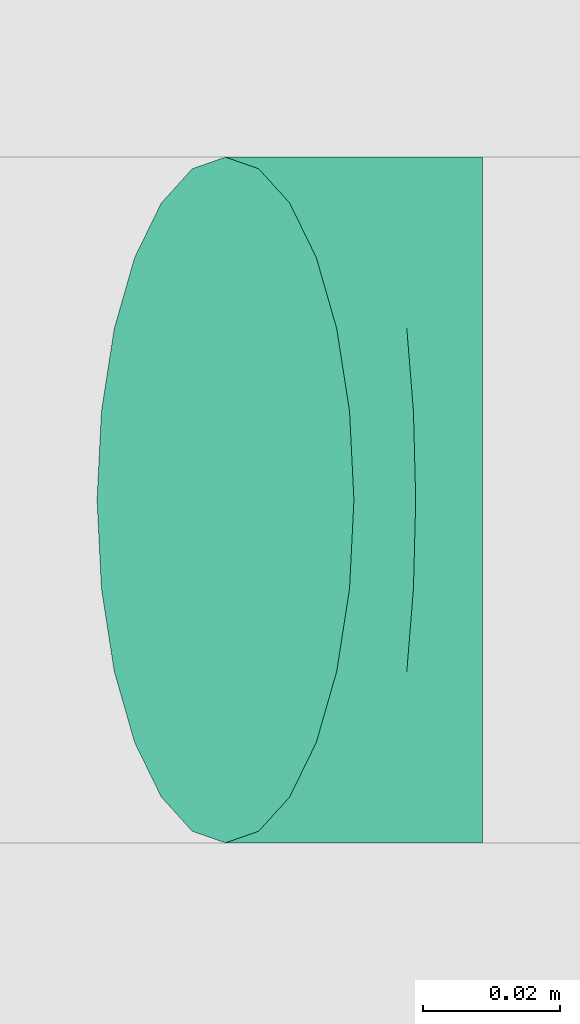
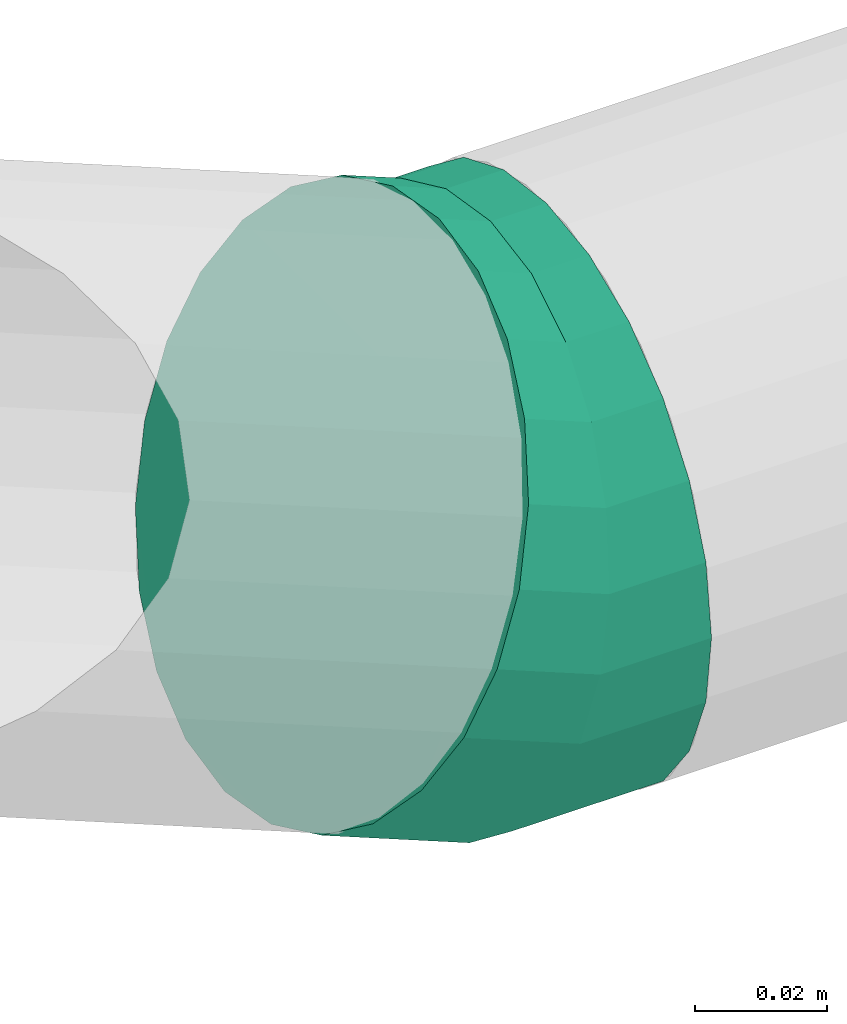
# One storey, part 216 of 337: 1 flow fitting.
"""IFC2X3 building model written with IfcOpenShell, lengths in millimetres."""

from ifc_helpers import new_model, entity, si_unit, converted_unit, derived_unit, direction, frame, origin, place, context, subcontext, project, spatial, faceted_brep, source, transform, mapped, material, type_object, type_shapes, element, save


model = new_model("IFC2X3")

# Units and contexts
model_context = context("Model", 3, precision=0.01, world=origin(), true_north=direction((6.12303176911189e-17, 1.0)))
body_context = subcontext(model_context, "Body", "Model", "MODEL_VIEW")
ifc_project = project(units=[si_unit("LENGTHUNIT", "METRE", prefix="MILLI"), si_unit("AREAUNIT", "SQUARE_METRE"), si_unit("VOLUMEUNIT", "CUBIC_METRE"), converted_unit("PLANEANGLEUNIT", "DEGREE", entity("IfcRatioMeasure", 0.0174532925199433), si_unit("PLANEANGLEUNIT", "RADIAN"), dimensions=[0, 0, 0, 0, 0, 0, 0]), si_unit("MASSUNIT", "GRAM", prefix="KILO"), derived_unit("MASSDENSITYUNIT", [(si_unit("MASSUNIT", "GRAM", prefix="KILO"), 1), (si_unit("LENGTHUNIT", "METRE"), -3)]), derived_unit("MOMENTOFINERTIAUNIT", [(si_unit("LENGTHUNIT", "METRE"), 4)]), si_unit("TIMEUNIT", "SECOND"), si_unit("FREQUENCYUNIT", "HERTZ"), si_unit("THERMODYNAMICTEMPERATUREUNIT", "DEGREE_CELSIUS"), derived_unit("THERMALTRANSMITTANCEUNIT", [(si_unit("MASSUNIT", "GRAM", prefix="KILO"), 1), (si_unit("THERMODYNAMICTEMPERATUREUNIT", "KELVIN"), -1), (si_unit("TIMEUNIT", "SECOND"), -3)]), derived_unit("VOLUMETRICFLOWRATEUNIT", [(si_unit("LENGTHUNIT", "METRE"), 3), (si_unit("TIMEUNIT", "SECOND"), -1)]), derived_unit("MASSFLOWRATEUNIT", [(si_unit("MASSUNIT", "GRAM", prefix="KILO"), 1), (si_unit("TIMEUNIT", "SECOND"), -1)]), derived_unit("ROTATIONALFREQUENCYUNIT", [(si_unit("TIMEUNIT", "SECOND"), -1)]), si_unit("ELECTRICCURRENTUNIT", "AMPERE"), si_unit("ELECTRICVOLTAGEUNIT", "VOLT"), si_unit("POWERUNIT", "WATT"), si_unit("FORCEUNIT", "NEWTON", prefix="KILO"), si_unit("ILLUMINANCEUNIT", "LUX"), si_unit("LUMINOUSFLUXUNIT", "LUMEN"), si_unit("LUMINOUSINTENSITYUNIT", "CANDELA"), derived_unit("USERDEFINED", [(si_unit("MASSUNIT", "GRAM", prefix="KILO"), -1), (si_unit("LENGTHUNIT", "METRE"), -2), (si_unit("TIMEUNIT", "SECOND"), 3), (si_unit("LUMINOUSFLUXUNIT", "LUMEN"), 1)]), derived_unit("LINEARVELOCITYUNIT", [(si_unit("LENGTHUNIT", "METRE"), 1), (si_unit("TIMEUNIT", "SECOND"), -1)]), si_unit("PRESSUREUNIT", "PASCAL"), derived_unit("USERDEFINED", [(si_unit("LENGTHUNIT", "METRE"), -2), (si_unit("MASSUNIT", "GRAM", prefix="KILO"), 1), (si_unit("TIMEUNIT", "SECOND"), -2)]), derived_unit("LINEARFORCEUNIT", [(si_unit("MASSUNIT", "GRAM", prefix="KILO"), 1), (si_unit("LENGTHUNIT", "METRE"), 1), (si_unit("TIMEUNIT", "SECOND"), -2), (si_unit("LENGTHUNIT", "METRE"), -1)]), derived_unit("PLANARFORCEUNIT", [(si_unit("MASSUNIT", "GRAM", prefix="KILO"), 1), (si_unit("LENGTHUNIT", "METRE"), 1), (si_unit("TIMEUNIT", "SECOND"), -2), (si_unit("LENGTHUNIT", "METRE"), -2)])], contexts=[model_context])

# Site, building, storey
site_placement = place(None, origin())
site = spatial("IfcSite", under=ifc_project, at=site_placement, CompositionType="ELEMENT")
building_placement = place(site_placement, origin())
building = spatial("IfcBuilding", under=site, at=building_placement, CompositionType="ELEMENT")
storey_placement = place(building_placement, origin())
storey = spatial("IfcBuildingStorey", under=building, at=storey_placement, CompositionType="ELEMENT", Elevation=0.0)

# Flow fitting
ifc_material = material()
duct_fitting_type = type_object("IfcDuctFittingType", PredefinedType="NOTDEFINED", material=ifc_material)
shared_shape = source(origin(), body_context, "Body", "Brep", [
    faceted_brep([(-19.44, 0.0, -50.0), (-19.44, -12.94, -48.3), (-19.44, -25.0, -43.3), (-19.44, -35.36, -35.36), (-19.44, -43.3, -25.0), (-19.44, -48.3, -12.94), (-19.44, -50.0, 0.0), (-19.44, -48.3, 12.94), (-19.44, -43.3, 25.0), (-19.44, -35.36, 35.36), (-19.44, -25.0, 43.3), (-19.44, -12.94, 48.3), (-19.44, 0.0, 50.0), (-19.44, 12.94, 48.3), (-19.44, 25.0, 43.3), (-19.44, 35.36, 35.36), (-19.44, 43.3, 25.0), (-19.44, 48.3, 12.94), (-19.44, 50.0, 0.0), (-19.44, 48.3, -12.94), (-19.44, 43.3, -25.0), (-19.44, 35.36, -35.36), (-19.44, 25.0, -43.3), (-19.44, 12.94, -48.3), (-2.52, 12.94, 48.3), (-4.86, 25.0, 43.3), (0.0, 0.0, 50.0), (-6.87, 35.36, 35.36), (-9.39, 48.3, 12.94), (-9.72, 50.0, 0.0), (-8.42, 43.3, 25.0), (-8.42, 43.3, -25.0), (-6.87, 35.36, -35.36), (-9.39, 48.3, -12.94), (-2.52, 12.94, -48.3), (0.0, 0.0, -50.0), (-4.86, 25.0, -43.3), (2.52, -12.94, -48.3), (4.86, -25.0, -43.3), (6.87, -35.36, -35.36), (8.42, -43.3, -25.0), (9.39, -48.3, -12.94), (9.72, -50.0, 0.0), (9.39, -48.3, 12.94), (8.42, -43.3, 25.0), (6.87, -35.36, 35.36), (4.86, -25.0, 43.3), (2.52, -12.94, 48.3), (18.02, 7.28, 50.0), (13.17, 19.28, 48.3), (8.66, 30.46, 43.3), (4.78, 40.06, 35.36), (1.8, 47.43, 25.0), (-0.07, 52.06, 12.94), (-0.71, 53.64, 0.0), (-0.07, 52.06, -12.94), (1.8, 47.43, -25.0), (4.78, 40.06, -35.36), (8.66, 30.46, -43.3), (13.17, 19.28, -48.3), (18.02, 7.28, -50.0), (22.87, -4.72, -48.3), (27.39, -15.9, -43.3), (31.27, -25.5, -35.36), (34.24, -32.87, -25.0), (36.11, -37.5, -12.94), (36.75, -39.08, 0.0), (36.11, -37.5, 12.94), (34.24, -32.87, 25.0), (31.27, -25.5, 35.36), (27.39, -15.9, 43.3), (22.87, -4.72, 48.3)], [[[0, 1, 2, 3, 4, 5, 6, 7, 8, 9, 10, 11, 12, 13, 14, 15, 16, 17, 18, 19, 20, 21, 22, 23]], [[24, 25, 14, 13]], [[26, 24, 13, 12]], [[14, 25, 27, 15]], [[28, 29, 18, 17]], [[30, 28, 17, 16]], [[15, 27, 30, 16]], [[20, 31, 32, 21]], [[33, 31, 20, 19]], [[18, 29, 33, 19]], [[34, 35, 0, 23]], [[36, 34, 23, 22]], [[32, 36, 22, 21]], [[2, 1, 37, 38]], [[3, 2, 38, 39]], [[0, 35, 37, 1]], [[5, 4, 40, 41]], [[6, 5, 41, 42]], [[39, 40, 4, 3]], [[6, 42, 43, 7]], [[7, 43, 44, 8]], [[8, 44, 45, 9]], [[10, 46, 47, 11]], [[11, 47, 26, 12]], [[9, 45, 46, 10]], [[24, 26, 48, 49]], [[25, 24, 49, 50]], [[27, 25, 50, 51]], [[28, 30, 52, 53]], [[29, 28, 53, 54]], [[27, 51, 52, 30]], [[29, 54, 55, 33]], [[33, 55, 56, 31]], [[31, 56, 57, 32]], [[36, 58, 59, 34]], [[34, 59, 60, 35]], [[36, 32, 57, 58]], [[35, 60, 61, 37]], [[37, 61, 62, 38]], [[38, 62, 63, 39]], [[40, 64, 65, 41]], [[41, 65, 66, 42]], [[39, 63, 64, 40]], [[43, 42, 66, 67]], [[44, 43, 67, 68]], [[45, 44, 68, 69]], [[47, 46, 70, 71]], [[26, 47, 71, 48]], [[69, 70, 46, 45]], [[59, 58, 57, 56, 55, 54, 53, 52, 51, 50, 49, 48, 71, 70, 69, 68, 67, 66, 65, 64, 63, 62, 61, 60]]]),
])
type_shapes(duct_fitting_type, [shared_shape])
flow_fitting_placement = place(storey_placement, frame((66383.7, 6263.46, 3140.0), z_axis=(0.0, 1.0, 0.0), x_axis=(-1.0, 0.0, 0.0)))
element("IfcFlowFitting", 1, at=flow_fitting_placement, inside=storey, type_object=duct_fitting_type, material=ifc_material, context=body_context, shape_type="MappedRepresentation", body=[
    mapped(shared_shape, transform((0.0, 0.0, 0.0), scale=1.0)),
])

save(model, "model.ifc")
